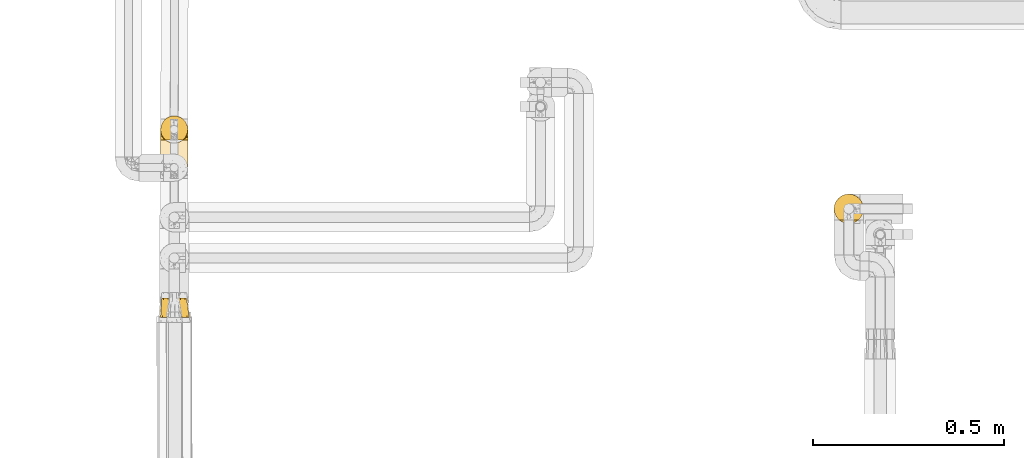
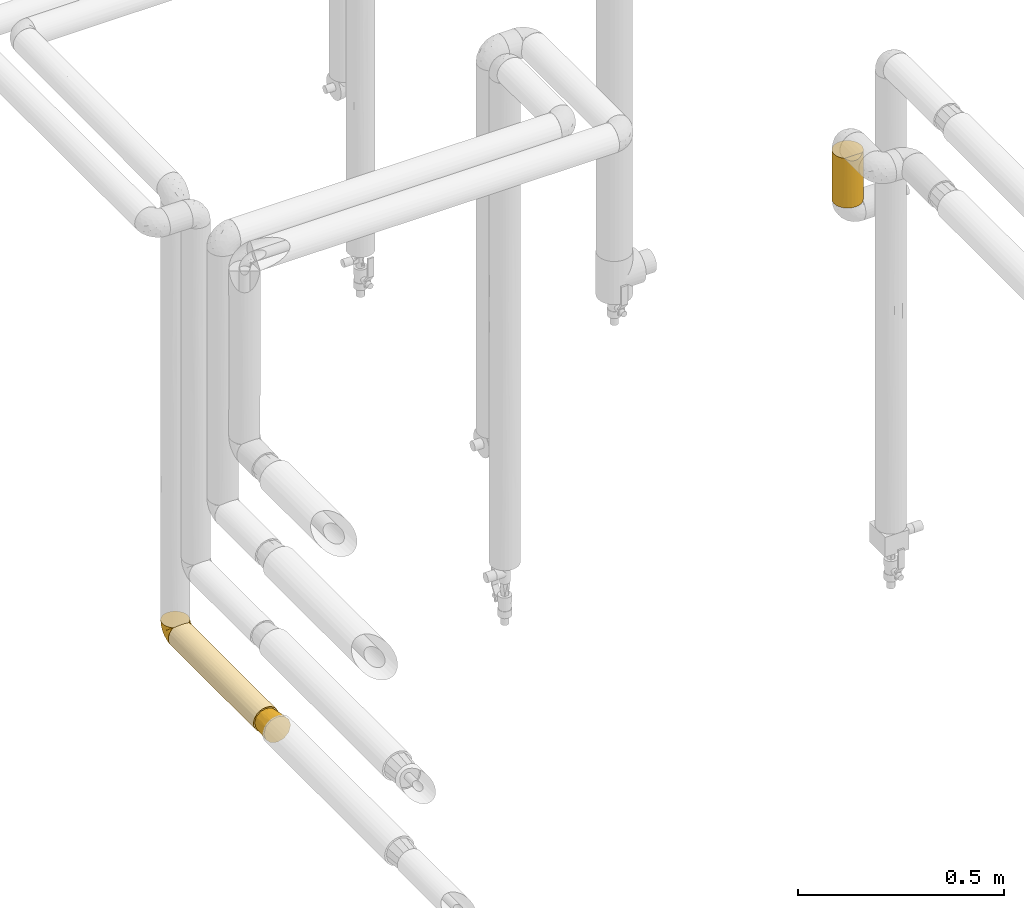
# One storey, part 81 of 827: 4 coverings.
"""IFC2X3 building model written with IfcOpenShell, lengths in millimetres."""

from ifc_helpers import new_model, entity, si_unit, converted_unit, derived_unit, direction, frame, origin, place, context, subcontext, project, spatial, faceted_brep, element, save


model = new_model("IFC2X3")

# Units and contexts
model_context = context("Model", 3, precision=0.01, world=origin(), true_north=direction((6.12303176911189e-17, 1.0)))
body_context = subcontext(model_context, "Body", "Model", "MODEL_VIEW")
ifc_project = project(units=[si_unit("LENGTHUNIT", "METRE", prefix="MILLI"), si_unit("AREAUNIT", "SQUARE_METRE"), si_unit("VOLUMEUNIT", "CUBIC_METRE"), converted_unit("PLANEANGLEUNIT", "DEGREE", entity("IfcRatioMeasure", 0.0174532925199433), si_unit("PLANEANGLEUNIT", "RADIAN"), dimensions=[0, 0, 0, 0, 0, 0, 0]), si_unit("MASSUNIT", "GRAM", prefix="KILO"), derived_unit("MASSDENSITYUNIT", [(si_unit("MASSUNIT", "GRAM", prefix="KILO"), 1), (si_unit("LENGTHUNIT", "METRE"), -3)]), derived_unit("MOMENTOFINERTIAUNIT", [(si_unit("LENGTHUNIT", "METRE"), 4)]), si_unit("TIMEUNIT", "SECOND"), si_unit("FREQUENCYUNIT", "HERTZ"), si_unit("THERMODYNAMICTEMPERATUREUNIT", "DEGREE_CELSIUS"), derived_unit("THERMALTRANSMITTANCEUNIT", [(si_unit("MASSUNIT", "GRAM", prefix="KILO"), 1), (si_unit("THERMODYNAMICTEMPERATUREUNIT", "KELVIN"), -1), (si_unit("TIMEUNIT", "SECOND"), -3)]), derived_unit("VOLUMETRICFLOWRATEUNIT", [(si_unit("LENGTHUNIT", "METRE"), 3), (si_unit("TIMEUNIT", "SECOND"), -1)]), derived_unit("MASSFLOWRATEUNIT", [(si_unit("MASSUNIT", "GRAM", prefix="KILO"), 1), (si_unit("TIMEUNIT", "SECOND"), -1)]), derived_unit("ROTATIONALFREQUENCYUNIT", [(si_unit("TIMEUNIT", "SECOND"), -1)]), si_unit("ELECTRICCURRENTUNIT", "AMPERE"), si_unit("ELECTRICVOLTAGEUNIT", "VOLT"), si_unit("POWERUNIT", "WATT"), si_unit("FORCEUNIT", "NEWTON", prefix="KILO"), si_unit("ILLUMINANCEUNIT", "LUX"), si_unit("LUMINOUSFLUXUNIT", "LUMEN"), si_unit("LUMINOUSINTENSITYUNIT", "CANDELA"), derived_unit("USERDEFINED", [(si_unit("MASSUNIT", "GRAM", prefix="KILO"), -1), (si_unit("LENGTHUNIT", "METRE"), -2), (si_unit("TIMEUNIT", "SECOND"), 3), (si_unit("LUMINOUSFLUXUNIT", "LUMEN"), 1)]), derived_unit("LINEARVELOCITYUNIT", [(si_unit("LENGTHUNIT", "METRE"), 1), (si_unit("TIMEUNIT", "SECOND"), -1)]), si_unit("PRESSUREUNIT", "PASCAL"), derived_unit("USERDEFINED", [(si_unit("LENGTHUNIT", "METRE"), -2), (si_unit("MASSUNIT", "GRAM", prefix="KILO"), 1), (si_unit("TIMEUNIT", "SECOND"), -2)]), derived_unit("LINEARFORCEUNIT", [(si_unit("MASSUNIT", "GRAM", prefix="KILO"), 1), (si_unit("LENGTHUNIT", "METRE"), 1), (si_unit("TIMEUNIT", "SECOND"), -2), (si_unit("LENGTHUNIT", "METRE"), -1)]), derived_unit("PLANARFORCEUNIT", [(si_unit("MASSUNIT", "GRAM", prefix="KILO"), 1), (si_unit("LENGTHUNIT", "METRE"), 1), (si_unit("TIMEUNIT", "SECOND"), -2), (si_unit("LENGTHUNIT", "METRE"), -2)])], contexts=[model_context])

# Site, building, storey
site_placement = place(None, origin())
site = spatial("IfcSite", under=ifc_project, at=site_placement, CompositionType="ELEMENT")
building_placement = place(site_placement, origin())
building = spatial("IfcBuilding", under=site, at=building_placement, CompositionType="ELEMENT")
storey_placement = place(building_placement, frame((0.0, 0.0, 28200.0)))
storey = spatial("IfcBuildingStorey", under=building, at=storey_placement, Name="08", CompositionType="ELEMENT", Elevation=28200.0)

# Coverings
covering_1_placement = place(storey_placement, frame((19653.77, 11848.56, 1380.45)))
element("IfcCovering", 1, at=covering_1_placement, inside=storey, Name=":ADSK_", ObjectType=":ADSK_", PredefinedType="INSULATION", context=body_context, shape_type="Brep", body=[
    faceted_brep([(77.51, 31.79, 148.62), (78.4, 40.0, 148.62), (77.09, 49.93, 148.62), (73.25, 59.2, 148.62), (67.15, 67.15, 148.62), (59.2, 73.25, 148.62), (49.93, 77.09, 148.62), (40.0, 78.4, 148.62), (30.06, 77.09, 148.62), (20.8, 73.25, 148.62), (12.84, 67.15, 148.62), (6.74, 59.2, 148.62), (2.9, 49.93, 148.62), (1.6, 40.0, 148.62), (2.48, 31.79, 148.62), (5.09, 23.98, 148.62), (9.31, 16.91, 148.62), (14.94, 10.9, 148.62), (65.05, 10.9, 148.62), (70.68, 16.91, 148.62), (74.9, 23.98, 148.62), (69.1, 14.94, 1.6), (63.08, 9.31, 1.6), (56.01, 5.09, 1.6), (48.2, 2.48, 1.6), (40.0, 1.6, 1.6), (30.06, 2.9, 1.6), (20.8, 6.74, 1.6), (12.84, 12.84, 1.6), (6.74, 20.8, 1.6), (2.9, 30.06, 1.6), (1.6, 40.0, 1.6), (2.9, 49.93, 1.6), (6.74, 59.2, 1.6), (12.84, 67.15, 1.6), (20.8, 73.25, 1.6), (30.06, 77.09, 1.6), (40.0, 78.4, 1.6), (48.2, 77.51, 1.6), (56.01, 74.9, 1.6), (63.08, 70.68, 1.6), (69.1, 65.05, 1.6), (46.78, 2.2, 139.92), (59.51, 6.92, 144.64), (53.36, 4.0, 141.72), (40.0, 1.6, 139.32), (73.07, 20.48, 5.57), (76.0, 26.63, 8.5), (77.79, 33.21, 10.29), (78.4, 40.0, 10.9), (77.79, 46.78, 10.29), (76.0, 53.36, 8.5), (73.07, 59.51, 5.57), (26.63, 4.0, 141.72), (33.21, 2.2, 139.92), (20.48, 6.92, 144.64)], [[[0, 1, 2, 3, 4, 5, 6, 7, 8, 9, 10, 11, 12, 13, 14, 15, 16, 17, 18, 19, 20]], [[21, 22, 23, 24, 25, 26, 27, 28, 29, 30, 31, 32, 33, 34, 35, 36, 37, 38, 39, 40, 41]], [[25, 24, 42]], [[23, 22, 43]], [[24, 23, 44]], [[42, 45, 25]], [[43, 44, 23]], [[18, 43, 22]], [[42, 24, 44]], [[22, 21, 18]], [[21, 46, 19]], [[47, 48, 0]], [[46, 47, 20]], [[19, 46, 20]], [[48, 1, 0]], [[0, 20, 47]], [[1, 48, 49]], [[21, 19, 18]], [[50, 51, 2]], [[52, 41, 3]], [[51, 52, 3]], [[49, 50, 1]], [[1, 50, 2]], [[51, 3, 2]], [[41, 4, 3]], [[5, 40, 39]], [[6, 39, 38]], [[7, 38, 37]], [[4, 40, 5]], [[5, 39, 6]], [[38, 7, 6]], [[40, 4, 41]], [[8, 7, 37, 36]], [[9, 8, 36, 35]], [[35, 34, 10, 9]], [[12, 11, 33, 32]], [[13, 12, 32, 31]], [[34, 33, 11, 10]], [[14, 31, 30]], [[15, 30, 29]], [[16, 29, 28]], [[13, 31, 14]], [[14, 30, 15]], [[29, 16, 15]], [[28, 17, 16]], [[53, 27, 26]], [[26, 25, 54]], [[45, 54, 25]], [[55, 17, 27]], [[54, 53, 26]], [[55, 27, 53]], [[27, 17, 28]], [[55, 53, 54, 45, 42, 44, 43, 18, 17]], [[41, 52, 51, 50, 49, 48, 47, 46, 21]]]),
])
covering_2_placement = place(storey_placement, frame((17889.48, 11654.18, 562.11)))
element("IfcCovering", 2, at=covering_2_placement, inside=storey, Name=":ADSK_", ObjectType=":ADSK_", PredefinedType="INSULATION", context=body_context, shape_type="Brep", body=[
    faceted_brep([(5.15, 414.03, 52.77), (9.43, 414.03, 59.55), (15.11, 414.03, 65.19), (59.25, 414.03, 65.3), (64.98, 414.03, 59.64), (69.3, 414.03, 52.85), (71.98, 414.03, 45.26), (72.9, 414.03, 37.25), (71.68, 414.03, 28.02), (68.12, 414.03, 19.42), (62.45, 414.03, 12.04), (55.07, 414.03, 6.37), (46.47, 414.03, 2.81), (37.25, 414.03, 1.6), (28.02, 414.03, 2.81), (19.42, 414.03, 6.37), (12.04, 414.03, 12.04), (6.37, 414.03, 19.42), (2.81, 414.03, 28.02), (1.6, 414.03, 37.25), (2.5, 414.03, 45.22), (28.02, 0.0, 71.68), (19.42, 0.0, 68.12), (12.04, 0.0, 62.45), (6.37, 0.0, 55.07), (2.81, 0.0, 46.47), (1.6, 0.0, 37.25), (2.81, 0.0, 28.02), (6.37, 0.0, 19.42), (12.04, 0.0, 12.04), (19.42, 0.0, 6.37), (28.02, 0.0, 2.81), (37.25, 0.0, 1.6), (46.47, 0.0, 2.81), (55.07, 0.0, 6.37), (62.45, 0.0, 12.04), (68.12, 0.0, 19.42), (71.68, 0.0, 28.02), (72.9, 0.0, 37.25), (71.68, 0.0, 46.47), (68.12, 0.0, 55.07), (62.45, 0.0, 62.45), (55.07, 0.0, 68.12), (46.47, 0.0, 71.68), (37.25, 0.0, 72.9), (65.53, 207.01, 15.54), (70.18, 207.01, 23.6), (44.2, 223.2, 2.28), (37.25, 205.54, 1.6), (37.25, 208.48, 1.6), (72.21, 190.9, 30.29), (72.9, 208.48, 37.25), (72.9, 205.54, 37.25), (58.95, 207.01, 8.96), (50.89, 207.01, 4.31), (30.29, 223.12, 2.28), (23.6, 207.01, 4.31), (2.28, 223.2, 30.29), (4.31, 207.01, 23.6), (15.54, 207.01, 8.96), (8.96, 207.01, 15.54), (1.6, 205.54, 37.25), (1.6, 208.48, 37.25), (3.61, 215.76, 49.07), (7.1, 221.17, 56.28), (29.54, 204.23, 72.05), (25.53, 408.33, 70.91), (31.3, 406.86, 72.4), (15.94, 190.64, 65.83), (11.14, 237.7, 61.53), (37.25, 197.89, 72.9), (20.08, 410.74, 68.49), (22.66, 200.36, 69.78), (37.25, 406.38, 72.9), (44.85, 203.65, 72.08), (43.15, 406.88, 72.4), (58.44, 191.76, 65.91), (51.73, 199.47, 69.82), (70.86, 215.58, 49.13), (67.33, 221.03, 56.37), (54.3, 410.76, 68.55), (48.88, 408.36, 70.94), (63.27, 237.24, 61.61)], [[[0, 1, 2, 3, 4, 5, 6, 7, 8, 9, 10, 11, 12, 13, 14, 15, 16, 17, 18, 19, 20]], [[21, 22, 23, 24, 25, 26, 27, 28, 29, 30, 31, 32, 33, 34, 35, 36, 37, 38, 39, 40, 41, 42, 43, 44]], [[45, 46, 36]], [[13, 47, 32, 48, 49]], [[37, 36, 46]], [[50, 37, 46]], [[7, 50, 8]], [[46, 45, 9]], [[35, 45, 36]], [[51, 52, 38, 50, 7]], [[10, 9, 45]], [[38, 37, 50]], [[53, 45, 35]], [[8, 46, 9]], [[54, 34, 33]], [[8, 50, 46]], [[34, 53, 35]], [[13, 12, 47]], [[53, 11, 10]], [[54, 53, 34]], [[47, 12, 54]], [[54, 11, 53]], [[45, 53, 10]], [[11, 54, 12]], [[33, 47, 54]], [[32, 47, 33]], [[55, 31, 56]], [[27, 57, 58]], [[55, 13, 49, 48, 32]], [[56, 31, 30]], [[55, 32, 31]], [[14, 56, 15]], [[56, 14, 55]], [[59, 16, 15]], [[59, 56, 30]], [[60, 59, 29]], [[19, 57, 26, 61, 62]], [[58, 28, 27]], [[57, 18, 58]], [[19, 18, 57]], [[60, 17, 16]], [[58, 60, 28]], [[26, 57, 27]], [[58, 17, 60]], [[59, 60, 16]], [[29, 59, 30]], [[17, 58, 18]], [[28, 60, 29]], [[13, 55, 14]], [[56, 59, 15]], [[63, 61, 25]], [[24, 64, 63]], [[65, 21, 44]], [[66, 65, 67]], [[68, 69, 23]], [[70, 65, 44]], [[25, 61, 26]], [[24, 63, 25]], [[20, 63, 0]], [[64, 1, 0]], [[61, 63, 20]], [[1, 64, 69]], [[71, 72, 66]], [[23, 69, 64]], [[63, 64, 0]], [[73, 67, 70]], [[23, 64, 24]], [[70, 67, 65]], [[20, 19, 62, 61]], [[72, 71, 68]], [[22, 21, 72]], [[65, 72, 21]], [[71, 2, 68]], [[66, 72, 65]], [[23, 22, 68]], [[72, 68, 22]], [[2, 69, 68]], [[69, 2, 1]], [[44, 74, 70]], [[74, 44, 43]], [[70, 74, 75]], [[76, 77, 42]], [[43, 42, 77]], [[78, 5, 79]], [[77, 74, 43]], [[77, 76, 80]], [[77, 80, 81]], [[81, 75, 74]], [[3, 80, 76]], [[75, 73, 70]], [[41, 40, 79]], [[41, 82, 76]], [[40, 39, 78]], [[78, 79, 40]], [[3, 82, 4]], [[6, 52, 51, 7]], [[52, 78, 39]], [[4, 79, 5]], [[41, 79, 82]], [[5, 78, 6]], [[52, 6, 78]], [[42, 41, 76]], [[79, 4, 82]], [[3, 76, 82]], [[81, 74, 77]], [[38, 52, 39]], [[71, 66, 67, 73, 75, 81, 80, 3, 2]]]),
])
covering_3_placement = place(storey_placement, frame((17889.48, 12066.61, 562.2)))
element("IfcCovering", 3, at=covering_3_placement, inside=storey, Name=":ADSK_", ObjectType=":ADSK_", PredefinedType="INSULATION", context=body_context, shape_type="Brep", body=[
    faceted_brep([(5.13, 1.6, 21.77), (9.38, 1.6, 15.01), (15.02, 1.6, 9.37), (21.78, 1.6, 5.12), (29.32, 1.6, 2.49), (37.25, 1.6, 1.6), (45.18, 1.6, 2.49), (52.72, 1.6, 5.13), (59.48, 1.6, 9.38), (65.12, 1.6, 15.02), (69.37, 1.6, 21.78), (72.0, 1.6, 29.32), (72.9, 1.6, 37.25), (72.01, 1.6, 45.15), (69.39, 1.6, 52.65), (65.18, 1.6, 59.39), (59.59, 1.6, 65.02), (57.53, 1.6, 65.02), (56.06, 1.6, 65.02), (54.3, 1.6, 65.02), (52.53, 1.6, 65.02), (50.77, 1.6, 65.02), (49.0, 1.6, 65.02), (47.24, 1.6, 65.02), (45.47, 1.6, 65.02), (43.71, 1.6, 65.02), (41.94, 1.6, 65.02), (40.18, 1.6, 65.02), (38.41, 1.6, 65.02), (36.65, 1.6, 65.02), (34.88, 1.6, 65.02), (33.12, 1.6, 65.02), (31.35, 1.6, 65.02), (29.3, 1.6, 65.02), (27.24, 1.6, 65.02), (25.18, 1.6, 65.02), (23.13, 1.6, 65.02), (21.07, 1.6, 65.02), (19.01, 1.6, 65.02), (16.96, 1.6, 65.02), (14.9, 1.6, 65.02), (9.3, 1.6, 59.38), (5.09, 1.6, 52.64), (2.48, 1.6, 45.13), (1.6, 1.6, 37.25), (2.49, 1.6, 29.31), (59.59, 1.82, 65.25), (65.19, 7.46, 65.25), (69.4, 14.2, 65.25), (72.01, 21.7, 65.25), (72.9, 29.6, 65.25), (71.68, 38.82, 65.25), (68.12, 47.42, 65.25), (62.45, 54.8, 65.25), (55.07, 60.47, 65.25), (46.47, 64.03, 65.25), (37.25, 65.25, 65.25), (28.02, 64.03, 65.25), (19.42, 60.47, 65.25), (12.04, 54.8, 65.25), (6.37, 47.42, 65.25), (2.81, 38.82, 65.25), (1.6, 29.6, 65.25), (2.48, 21.7, 65.25), (5.09, 14.2, 65.25), (9.3, 7.46, 65.25), (14.9, 1.82, 65.25), (15.93, 1.82, 65.25), (17.69, 1.82, 65.25), (19.09, 1.82, 65.25), (20.49, 1.82, 65.25), (21.88, 1.82, 65.25), (23.28, 1.82, 65.25), (24.68, 1.82, 65.25), (26.07, 1.82, 65.25), (27.47, 1.82, 65.25), (28.87, 1.82, 65.25), (30.26, 1.82, 65.25), (31.66, 1.82, 65.25), (33.06, 1.82, 65.25), (34.45, 1.82, 65.25), (35.85, 1.82, 65.25), (37.25, 1.82, 65.25), (39.01, 1.82, 65.25), (40.77, 1.82, 65.25), (42.54, 1.82, 65.25), (44.3, 1.82, 65.25), (46.07, 1.82, 65.25), (47.83, 1.82, 65.25), (49.6, 1.82, 65.25), (51.36, 1.82, 65.25), (53.42, 1.82, 65.25), (55.48, 1.82, 65.25), (57.53, 1.82, 65.25), (24.13, 1.75, 65.08), (22.58, 1.76, 65.09), (46.76, 1.76, 65.09), (45.43, 1.76, 65.1), (51.49, 1.74, 65.08), (35.2, 1.76, 65.09), (58.19, 1.75, 65.09), (56.8, 1.75, 65.09), (32.4, 1.75, 65.09), (30.96, 1.76, 65.1), (16.26, 1.74, 65.08), (14.9, 1.75, 65.09), (28.17, 1.74, 65.08), (26.81, 1.76, 65.09), (55.49, 1.75, 65.08), (44.1, 1.75, 65.09), (42.83, 1.74, 65.07), (36.55, 1.76, 65.1), (37.92, 1.76, 65.09), (29.48, 1.76, 65.1), (39.3, 1.73, 65.07), (48.12, 1.74, 65.07), (49.39, 1.75, 65.09), (17.58, 1.74, 65.08), (33.81, 1.75, 65.09), (41.72, 1.78, 65.13), (54.15, 1.76, 65.1), (52.82, 1.76, 65.09), (40.57, 1.75, 65.09), (21.1, 1.76, 65.1), (19.79, 1.75, 65.09), (59.59, 1.75, 65.09), (25.46, 1.76, 65.09), (70.91, 13.11, 53.74), (68.25, 8.18, 57.19), (72.9, 25.84, 51.25), (72.9, 28.13, 59.77), (72.9, 15.6, 41.0), (64.57, 5.2, 61.64), (72.9, 20.72, 46.12), (72.9, 7.07, 38.71), (46.9, 35.56, 13.0), (49.02, 16.98, 5.55), (37.25, 25.95, 6.44), (72.16, 35.4, 55.39), (72.12, 32.74, 48.48), (65.96, 43.51, 39.63), (58.95, 53.51, 43.5), (65.53, 49.6, 52.38), (70.18, 40.07, 49.31), (70.18, 42.61, 58.01), (67.43, 20.45, 22.23), (67.43, 10.52, 19.14), (62.46, 14.87, 13.73), (72.19, 24.92, 39.1), (53.36, 34.61, 15.38), (43.86, 61.84, 46.7), (50.89, 60.43, 49.4), (37.25, 14.29, 4.12), (58.95, 57.0, 55.35), (55.84, 42.79, 23.83), (59.19, 33.34, 19.0), (71.35, 21.53, 32.44), (70.9, 11.52, 26.73), (56.22, 12.66, 8.12), (67.42, 34.11, 31.34), (70.63, 32.29, 38.81), (61.45, 24.41, 16.11), (56.22, 24.95, 11.96), (48.22, 44.19, 20.31), (51.43, 56.24, 38.81), (45.24, 56.83, 35.48), (50.08, 50.94, 28.94), (43.45, 50.38, 25.21), (37.25, 46.6, 20.24), (37.25, 36.28, 13.34), (37.25, 62.72, 52.55), (59.41, 47.39, 33.16), (62.46, 38.92, 27.33), (64.67, 29.55, 22.86), (68.35, 26.82, 27.48), (37.25, 60.4, 40.89), (37.25, 53.5, 30.56), (4.31, 41.8, 54.41), (30.45, 61.8, 46.71), (25.32, 49.33, 26.31), (27.59, 35.54, 12.98), (12.04, 14.87, 13.72), (18.28, 12.65, 8.12), (8.96, 47.44, 46.04), (15.54, 56.06, 51.06), (16.32, 50.17, 35.69), (7.06, 20.44, 22.22), (7.06, 10.52, 19.13), (3.6, 11.52, 26.72), (19.36, 38.79, 19.65), (2.28, 33.87, 51.87), (1.6, 25.84, 51.25), (1.6, 27.72, 58.25), (1.6, 7.07, 38.71), (25.07, 62.13, 54.36), (8.96, 50.52, 56.5), (29.08, 56.47, 34.9), (23.6, 58.39, 43.16), (25.48, 16.98, 5.54), (7.69, 39.3, 35.66), (4.1, 38.56, 47.21), (18.28, 24.94, 11.95), (2.18, 30.34, 46.27), (2.39, 26.49, 39.95), (1.6, 15.6, 41.0), (1.6, 20.72, 46.12), (12.04, 26.6, 18.27), (3.15, 21.54, 32.43), (2.24, 35.7, 58.69), (12.04, 38.91, 27.31), (6.5, 30.65, 29.52), (11.64, 44.9, 35.02), (3.92, 34.09, 40.81), (3.58, 13.11, 53.74), (6.24, 9.65, 58.66), (9.92, 5.2, 61.64)], [[[0, 1, 2, 3, 4, 5, 6, 7, 8, 9, 10, 11, 12, 13, 14, 15, 16, 17, 18, 19, 20, 21, 22, 23, 24, 25, 26, 27, 28, 29, 30, 31, 32, 33, 34, 35, 36, 37, 38, 39, 40, 41, 42, 43, 44, 45]], [[46, 47, 48, 49, 50, 51, 52, 53, 54, 55, 56, 57, 58, 59, 60, 61, 62, 63, 64, 65, 66, 67, 68, 69, 70, 71, 72, 73, 74, 75, 76, 77, 78, 79, 80, 81, 82, 83, 84, 85, 86, 87, 88, 89, 90, 91, 92, 93]], [[94, 72, 95]], [[96, 87, 97]], [[20, 98, 21]], [[99, 81, 80]], [[100, 93, 101]], [[102, 103, 32]], [[104, 105, 40]], [[67, 105, 104]], [[106, 107, 34]], [[18, 101, 108]], [[109, 85, 110]], [[36, 94, 95]], [[81, 111, 82]], [[29, 28, 112]], [[17, 101, 18]], [[103, 113, 33]], [[24, 96, 97]], [[28, 114, 112]], [[115, 22, 116]], [[31, 102, 32]], [[68, 104, 117]], [[31, 118, 102]], [[84, 119, 85]], [[120, 91, 121]], [[23, 22, 115]], [[114, 27, 122]], [[123, 37, 95]], [[117, 124, 69]], [[67, 66, 105]], [[104, 39, 117]], [[123, 124, 37]], [[100, 17, 16]], [[100, 125, 46]], [[17, 100, 101]], [[107, 126, 35]], [[92, 108, 101]], [[115, 88, 96]], [[114, 122, 83]], [[101, 93, 92]], [[93, 100, 46]], [[16, 125, 100]], [[108, 19, 18]], [[120, 121, 19]], [[108, 92, 120]], [[19, 108, 120]], [[67, 104, 68]], [[39, 104, 40]], [[69, 68, 117]], [[117, 39, 38]], [[70, 124, 123]], [[124, 70, 69]], [[38, 124, 117]], [[124, 38, 37]], [[72, 71, 95]], [[71, 123, 95]], [[71, 70, 123]], [[126, 94, 35]], [[37, 36, 95]], [[75, 74, 107]], [[73, 72, 94]], [[94, 36, 35]], [[94, 126, 73]], [[74, 73, 126]], [[106, 76, 75]], [[76, 106, 113]], [[113, 106, 33]], [[107, 35, 34]], [[106, 34, 33]], [[126, 107, 74]], [[107, 106, 75]], [[78, 77, 103]], [[77, 113, 103]], [[77, 76, 113]], [[102, 78, 103]], [[33, 32, 103]], [[80, 79, 118]], [[102, 118, 79]], [[112, 111, 29]], [[118, 31, 30]], [[79, 78, 102]], [[99, 111, 81]], [[112, 82, 111]], [[111, 99, 29]], [[30, 29, 99]], [[112, 83, 82]], [[27, 114, 28]], [[99, 118, 30]], [[118, 99, 80]], [[114, 83, 112]], [[84, 83, 122]], [[109, 110, 25]], [[122, 27, 26]], [[119, 110, 85]], [[20, 19, 121]], [[25, 110, 26]], [[91, 120, 92]], [[90, 98, 121]], [[121, 91, 90]], [[23, 115, 96]], [[88, 115, 116]], [[116, 98, 89]], [[89, 88, 116]], [[23, 96, 24]], [[87, 96, 88]], [[25, 24, 109]], [[97, 87, 86]], [[90, 89, 98]], [[116, 22, 21]], [[122, 26, 119]], [[86, 85, 109]], [[109, 97, 86]], [[97, 109, 24]], [[110, 119, 26]], [[122, 119, 84]], [[121, 98, 20]], [[21, 98, 116]], [[48, 127, 49]], [[48, 47, 128]], [[49, 129, 130, 50]], [[129, 49, 127]], [[131, 127, 13]], [[46, 125, 132]], [[16, 15, 132]], [[127, 128, 14]], [[127, 131, 133, 129]], [[14, 13, 127]], [[13, 12, 134, 131]], [[46, 132, 47]], [[48, 128, 127]], [[47, 132, 128]], [[15, 128, 132]], [[125, 16, 132]], [[15, 14, 128]], [[135, 136, 137]], [[138, 129, 139]], [[140, 141, 142]], [[143, 144, 138]], [[145, 146, 147]], [[133, 148, 139]], [[134, 12, 11]], [[136, 135, 149]], [[150, 55, 151]], [[136, 6, 152]], [[153, 54, 53]], [[52, 144, 142]], [[52, 142, 53]], [[54, 153, 151]], [[144, 52, 51]], [[154, 155, 149]], [[156, 131, 157]], [[134, 11, 157]], [[8, 7, 158]], [[147, 9, 8]], [[157, 131, 134]], [[157, 11, 10]], [[146, 157, 10]], [[159, 140, 160]], [[157, 145, 156]], [[161, 162, 155]], [[161, 147, 162]], [[154, 149, 163]], [[150, 164, 165]], [[136, 7, 6]], [[137, 136, 152]], [[162, 158, 136]], [[54, 151, 55]], [[158, 147, 8]], [[166, 167, 165]], [[9, 146, 10]], [[164, 166, 165]], [[168, 135, 137, 169]], [[55, 150, 170]], [[154, 171, 172]], [[139, 148, 160]], [[140, 142, 143]], [[153, 142, 141]], [[51, 50, 130]], [[145, 173, 174]], [[156, 160, 148]], [[6, 5, 152]], [[136, 158, 7]], [[147, 158, 162]], [[147, 146, 9]], [[157, 146, 145]], [[160, 140, 143]], [[140, 172, 171]], [[139, 143, 138]], [[173, 159, 174]], [[170, 150, 175]], [[170, 56, 55]], [[167, 168, 176]], [[176, 175, 165]], [[150, 165, 175]], [[163, 167, 166]], [[176, 165, 167]], [[164, 150, 151]], [[151, 141, 164]], [[171, 164, 141]], [[154, 163, 166]], [[163, 135, 168]], [[166, 164, 171]], [[155, 154, 172]], [[166, 171, 154]], [[140, 171, 141]], [[173, 155, 172]], [[149, 155, 162]], [[159, 173, 172]], [[161, 145, 147]], [[140, 159, 172]], [[174, 160, 156]], [[136, 149, 162]], [[149, 135, 163]], [[155, 173, 161]], [[145, 161, 173]], [[160, 174, 159]], [[156, 148, 131]], [[156, 145, 174]], [[142, 153, 53]], [[151, 153, 141]], [[138, 51, 130]], [[142, 144, 143]], [[51, 138, 144]], [[129, 138, 130]], [[133, 139, 129]], [[160, 143, 139]], [[168, 167, 163]], [[131, 148, 133]], [[60, 177, 61]], [[175, 178, 170]], [[179, 168, 180]], [[178, 57, 170]], [[181, 182, 2]], [[183, 184, 185]], [[186, 187, 188]], [[189, 185, 179]], [[190, 191, 192]], [[45, 193, 188]], [[194, 184, 58]], [[45, 44, 193]], [[59, 195, 60]], [[60, 195, 177]], [[0, 45, 188]], [[196, 179, 197]], [[180, 137, 198]], [[183, 199, 200]], [[201, 182, 181]], [[1, 181, 2]], [[57, 178, 194]], [[198, 3, 182]], [[198, 152, 4]], [[1, 0, 187]], [[190, 202, 191]], [[203, 204, 205]], [[206, 201, 181]], [[186, 188, 207]], [[188, 204, 207]], [[3, 198, 4]], [[58, 184, 59]], [[187, 181, 1]], [[180, 198, 201]], [[206, 181, 186]], [[180, 189, 179]], [[3, 2, 182]], [[180, 168, 169, 137]], [[204, 188, 193]], [[177, 190, 208]], [[209, 210, 199]], [[210, 186, 207]], [[185, 184, 197]], [[195, 184, 183]], [[205, 202, 203]], [[210, 209, 206]], [[179, 185, 197]], [[211, 209, 199]], [[196, 197, 178]], [[180, 201, 189]], [[152, 198, 137]], [[152, 5, 4]], [[61, 208, 62]], [[198, 182, 201]], [[188, 187, 0]], [[181, 187, 186]], [[203, 210, 207]], [[202, 205, 191]], [[199, 210, 212]], [[57, 56, 170]], [[176, 196, 175]], [[178, 197, 194]], [[179, 176, 168]], [[175, 196, 178]], [[176, 179, 196]], [[184, 194, 197]], [[58, 57, 194]], [[208, 190, 192]], [[200, 190, 177]], [[206, 189, 201]], [[185, 189, 209]], [[62, 208, 192]], [[177, 208, 61]], [[210, 206, 186]], [[189, 206, 209]], [[200, 199, 212]], [[211, 183, 185]], [[184, 195, 59]], [[177, 195, 183]], [[183, 200, 177]], [[202, 200, 212]], [[200, 202, 190]], [[202, 212, 203]], [[210, 203, 212]], [[204, 203, 207]], [[183, 211, 199]], [[185, 209, 211]], [[63, 62, 192, 191]], [[64, 63, 213]], [[64, 213, 214]], [[65, 215, 66]], [[213, 191, 205, 204]], [[43, 204, 193, 44]], [[65, 214, 215]], [[42, 213, 43]], [[215, 105, 66]], [[41, 214, 42]], [[40, 105, 215]], [[65, 64, 214]], [[40, 215, 41]], [[213, 63, 191]], [[42, 214, 213]], [[204, 43, 213]], [[214, 41, 215]]]),
])
covering_4_placement = place(storey_placement, frame((17889.43, 11603.18, 560.26)))
element("IfcCovering", 4, at=covering_4_placement, inside=storey, Name=":ADSK_", ObjectType=":ADSK_", PredefinedType="INSULATION", context=body_context, shape_type="Brep", body=[
    faceted_brep([(67.62, 51.0, 47.22), (69.79, 51.0, 39.1), (67.62, 51.0, 30.97), (65.44, 51.0, 22.85), (59.49, 51.0, 16.9), (53.54, 51.0, 10.95), (45.42, 51.0, 8.77), (37.29, 51.0, 6.6), (29.17, 51.0, 8.77), (21.04, 51.0, 10.95), (15.1, 51.0, 16.9), (9.15, 51.0, 22.85), (6.97, 51.0, 30.97), (4.79, 51.0, 39.1), (6.97, 51.0, 47.22), (9.15, 51.0, 55.35), (15.1, 51.0, 61.29), (21.04, 51.0, 67.24), (29.17, 51.0, 69.42), (37.29, 51.0, 71.6), (45.42, 51.0, 69.42), (53.54, 51.0, 67.24), (59.49, 51.0, 61.29), (65.44, 51.0, 55.35), (20.35, 0.0, 71.57), (13.48, 0.0, 64.71), (6.62, 0.0, 57.85), (3.52, 0.0, 46.29), (1.6, 0.0, 39.1), (4.11, 0.0, 29.72), (6.62, 0.0, 20.35), (13.48, 0.0, 13.48), (20.35, 0.0, 6.62), (31.9, 0.0, 3.52), (39.1, 0.0, 1.6), (48.47, 0.0, 4.11), (57.85, 0.0, 6.62), (64.71, 0.0, 13.48), (71.57, 0.0, 20.35), (74.67, 0.0, 31.91), (76.6, 0.0, 39.1), (74.08, 0.0, 48.47), (71.57, 0.0, 57.85), (64.71, 0.0, 64.71), (57.85, 0.0, 71.57), (46.28, 0.0, 74.67), (39.1, 0.0, 76.6), (29.72, 0.0, 74.08), (70.53, 25.5, 25.7), (72.37, 26.64, 32.29), (67.05, 25.5, 19.28), (46.89, 25.5, 5.19), (59.5, 25.5, 11.33), (53.27, 25.5, 7.51), (73.08, 26.37, 39.1), (38.16, 26.37, 4.18), (24.8, 25.5, 6.76), (31.34, 26.64, 4.88), (18.38, 25.5, 10.24), (4.29, 25.5, 30.4), (10.43, 25.5, 17.79), (6.61, 25.5, 24.02), (3.25, 26.44, 39.1), (5.86, 25.5, 52.49), (3.94, 26.64, 45.9), (9.34, 25.5, 58.91), (29.5, 25.5, 73.0), (16.89, 25.5, 66.86), (23.12, 25.5, 70.68), (38.16, 26.44, 74.0), (51.59, 25.5, 71.43), (44.96, 26.64, 73.31), (58.01, 25.5, 67.95), (72.1, 25.5, 47.79), (65.96, 25.5, 60.4), (69.78, 25.5, 54.17)], [[[0, 1, 2, 3, 4, 5, 6, 7, 8, 9, 10, 11, 12, 13, 14, 15, 16, 17, 18, 19, 20, 21, 22, 23]], [[24, 25, 26, 27, 28, 29, 30, 31, 32, 33, 34, 35, 36, 37, 38, 39, 40, 41, 42, 43, 44, 45, 46, 47]], [[39, 48, 49]], [[49, 40, 39]], [[48, 39, 38]], [[3, 2, 48]], [[50, 3, 48]], [[48, 2, 49]], [[7, 6, 51]], [[52, 50, 37]], [[50, 48, 38]], [[5, 52, 53]], [[53, 52, 36]], [[37, 36, 52]], [[50, 38, 37]], [[54, 40, 49, 1]], [[52, 4, 50]], [[4, 3, 50]], [[4, 52, 5]], [[51, 6, 53]], [[53, 35, 51]], [[53, 36, 35]], [[1, 49, 2]], [[6, 5, 53]], [[34, 55, 7, 51]], [[34, 51, 35]], [[33, 56, 57]], [[57, 34, 33]], [[56, 33, 32]], [[9, 8, 56]], [[58, 9, 56]], [[56, 8, 57]], [[13, 12, 59]], [[60, 58, 31]], [[58, 56, 32]], [[11, 60, 61]], [[61, 60, 30]], [[31, 30, 60]], [[58, 32, 31]], [[55, 34, 57, 7]], [[60, 10, 58]], [[10, 9, 58]], [[10, 60, 11]], [[59, 12, 61]], [[61, 29, 59]], [[61, 30, 29]], [[7, 57, 8]], [[12, 11, 61]], [[28, 62, 13, 59]], [[28, 59, 29]], [[27, 63, 64]], [[64, 28, 27]], [[63, 27, 26]], [[15, 14, 63]], [[65, 15, 63]], [[63, 14, 64]], [[19, 18, 66]], [[67, 65, 25]], [[65, 63, 26]], [[17, 67, 68]], [[68, 67, 24]], [[25, 24, 67]], [[65, 26, 25]], [[62, 28, 64, 13]], [[67, 16, 65]], [[16, 15, 65]], [[16, 67, 17]], [[66, 18, 68]], [[68, 47, 66]], [[68, 24, 47]], [[13, 64, 14]], [[18, 17, 68]], [[46, 69, 19, 66]], [[46, 66, 47]], [[45, 70, 71]], [[71, 46, 45]], [[70, 45, 44]], [[21, 20, 70]], [[72, 21, 70]], [[70, 20, 71]], [[1, 0, 73]], [[74, 72, 43]], [[72, 70, 44]], [[23, 74, 75]], [[75, 74, 42]], [[43, 42, 74]], [[72, 44, 43]], [[69, 46, 71, 19]], [[74, 22, 72]], [[22, 21, 72]], [[22, 74, 23]], [[73, 0, 75]], [[75, 41, 73]], [[75, 42, 41]], [[19, 71, 20]], [[0, 23, 75]], [[40, 54, 1, 73]], [[40, 73, 41]]]),
])

save(model, "model.ifc")
